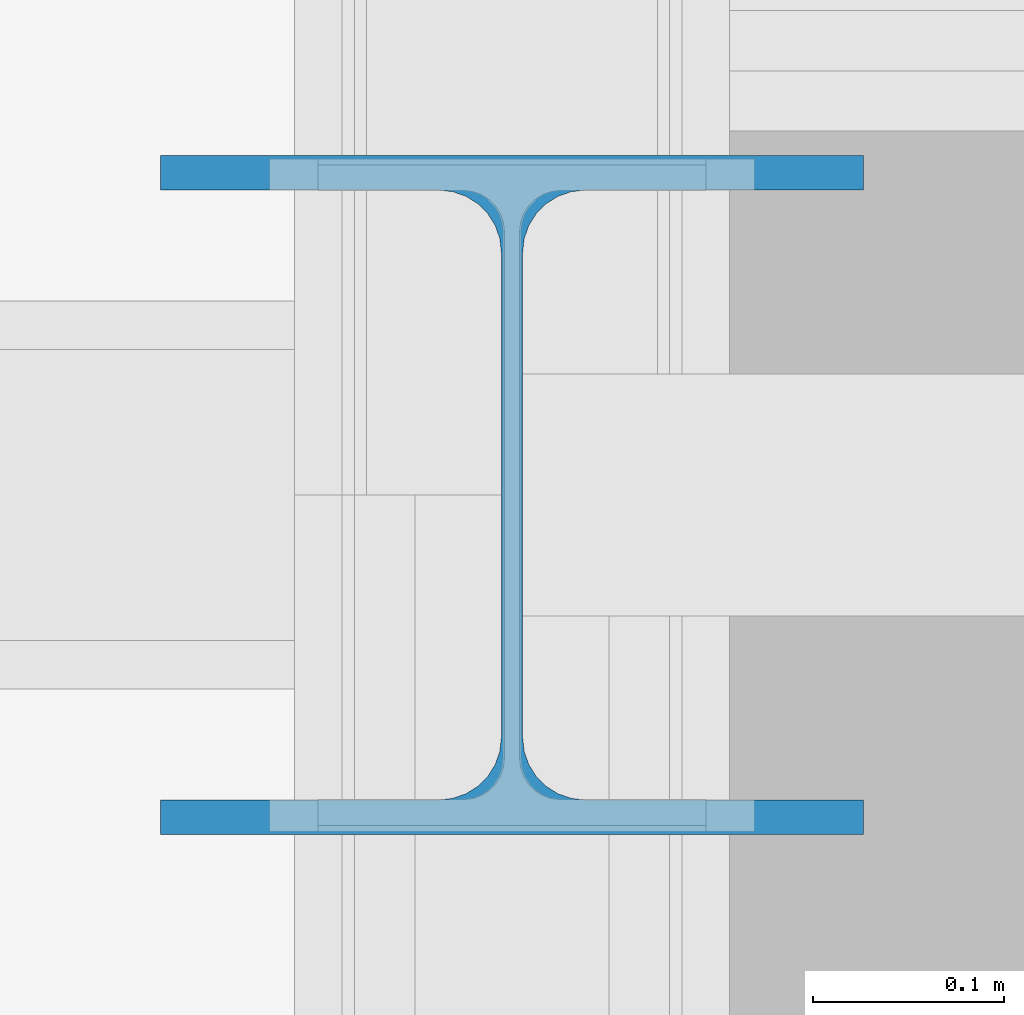
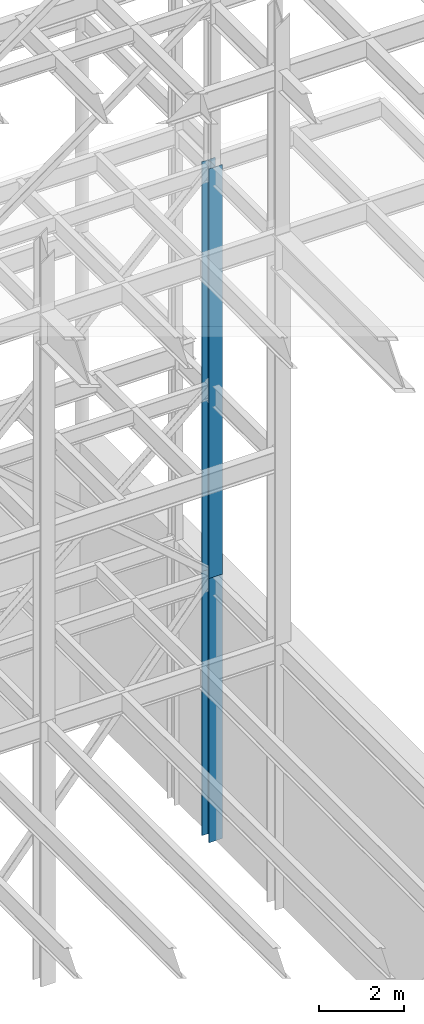
# One storey, part 119 of 150: 2 columns.
"""IFC2X3 building model written with IfcOpenShell, lengths in millimetres."""

from ifc_helpers import new_model, si_unit, frame, origin_with_axes, origin_2d_with_axis, place, context, subcontext, project, spatial, i_section, extrude, material, type_object, element, save


model = new_model("IFC2X3")

# Units and contexts
model_context = context("Model", 3, precision=1e-05, world=origin_with_axes())
body_context = subcontext(model_context, "Body", "Model", "MODEL_VIEW")
ifc_project = project(units=[si_unit("LENGTHUNIT", "METRE", prefix="MILLI"), si_unit("AREAUNIT", "SQUARE_METRE"), si_unit("VOLUMEUNIT", "CUBIC_METRE"), si_unit("MASSUNIT", "GRAM", prefix="KILO"), si_unit("TIMEUNIT", "SECOND"), si_unit("PLANEANGLEUNIT", "RADIAN"), si_unit("SOLIDANGLEUNIT", "STERADIAN"), si_unit("THERMODYNAMICTEMPERATUREUNIT", "DEGREE_CELSIUS"), si_unit("LUMINOUSINTENSITYUNIT", "LUMEN")], contexts=[model_context])

# Site, building, storey
site_placement = place(None, origin_with_axes())
site = spatial("IfcSite", under=ifc_project, at=site_placement, CompositionType="ELEMENT")
building_placement = place(site_placement, origin_with_axes())
building = spatial("IfcBuilding", under=site, at=building_placement, Name="Undefined", CompositionType="ELEMENT")
storey_placement = place(building_placement, origin_with_axes())
storey = spatial("IfcBuildingStorey", under=building, at=storey_placement, Name="Undefined", CompositionType="ELEMENT", Elevation=0.0)

# Columns
ifc_material = material(Name="STEEL/A992")
column_type = type_object("IfcColumnType", Name="W14X90", PredefinedType="NOTDEFINED")
column_1_placement = place(storey_placement, frame((88595.2, 25628.6, 23774.4), z_axis=(0.0, 0.0, 1.0), x_axis=(1.0, 0.0, 0.0)))
element("IfcColumn", 1, at=column_1_placement, inside=storey, type_object=column_type, material=ifc_material, Name="COLUMN", ObjectType="W14X90", context=body_context, shape_type="SweptSolid", body=[
    extrude(i_section(OverallWidth=368.3, OverallDepth=355.6, WebThickness=11.1125, FlangeThickness=18.034, FilletRadius=32.7659, at=origin_2d_with_axis()), frame((0.0, 0.0, 11811.0), z_axis=(0.0, 0.0, -1.0), x_axis=(-1.0, 0.0, 0.0)), (0.0, 0.0, 1.0), 11811.0),
])
column_2_placement = place(storey_placement, frame((88595.2, 25628.6, 16154.4), z_axis=(0.0, 0.0, 1.0), x_axis=(1.0, 0.0, 0.0)))
element("IfcColumn", 2, at=column_2_placement, inside=storey, type_object=column_type, material=ifc_material, Name="COLUMN", ObjectType="W14X90", context=body_context, shape_type="SweptSolid", body=[
    extrude(i_section(OverallWidth=368.3, OverallDepth=355.6, WebThickness=11.1125, FlangeThickness=18.034, FilletRadius=32.7659, at=origin_2d_with_axis()), frame((0.0, 0.0, 7620.0), z_axis=(0.0, 0.0, -1.0), x_axis=(-1.0, 0.0, 0.0)), (0.0, 0.0, 1.0), 7620.0),
])

save(model, "model.ifc")
